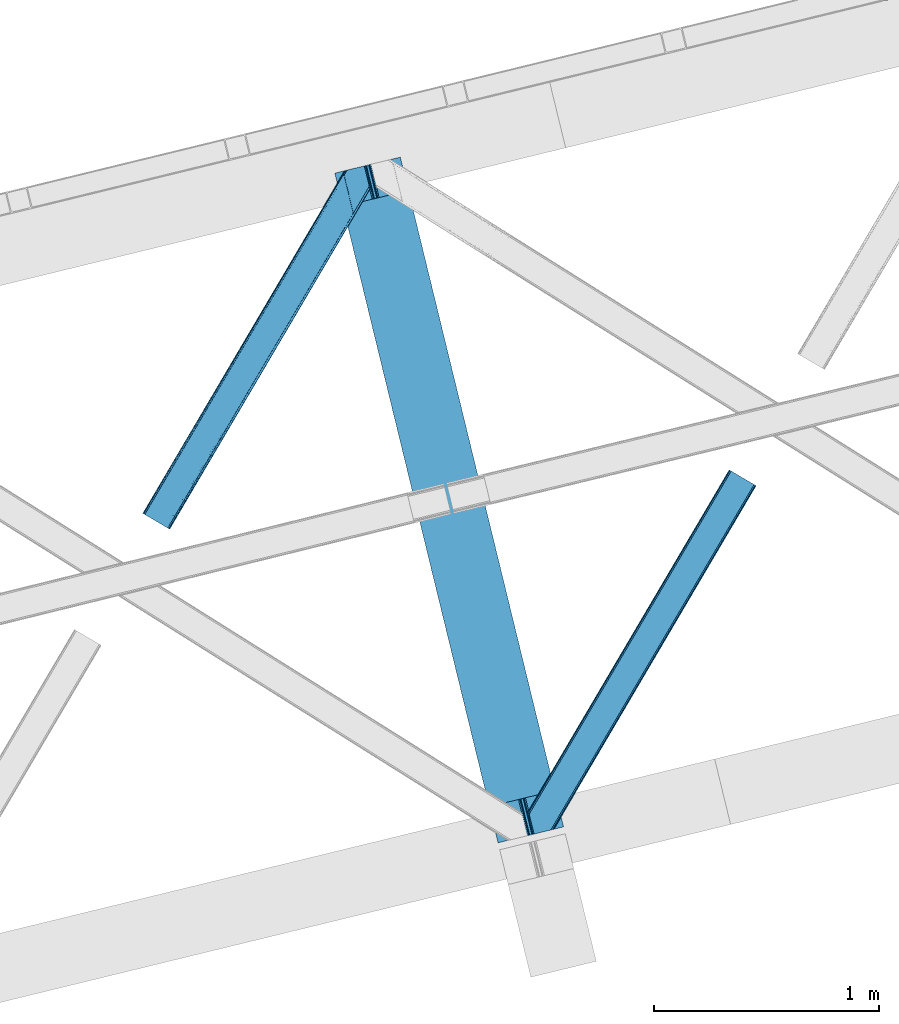
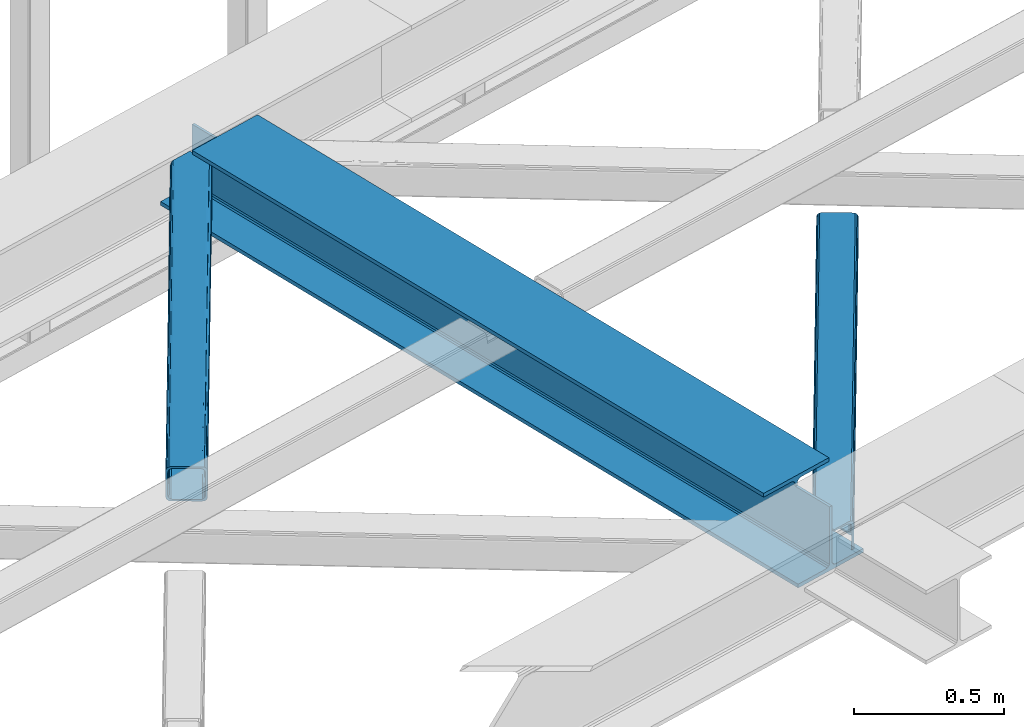
# One storey, part 23 of 67: 2 members, 1 beam.
"""IFC4 building model written with IfcOpenShell, lengths in millimetres."""

from ifc_helpers import new_model, entity, si_unit, converted_unit, derived_unit, direction, frame, origin, place, context, subcontext, project, spatial, triangles, polygons, material, type_object, element, save


model = new_model("IFC4")

# Units and contexts
model_context = context("Model", 3, precision=0.01, world=origin(), true_north=direction((6.12303176911189e-17, 1.0)))
plan_context = context("Plan", 3, precision=0.01, world=origin(), true_north=direction((6.12303176911189e-17, 1.0)))
body_context = subcontext(model_context, "Body", "Model", "MODEL_VIEW")
ifc_project = project(units=[si_unit("LENGTHUNIT", "METRE", prefix="MILLI"), si_unit("AREAUNIT", "SQUARE_METRE"), si_unit("VOLUMEUNIT", "CUBIC_METRE"), converted_unit("PLANEANGLEUNIT", "DEGREE", entity("IfcRatioMeasure", 0.0174532925199433), si_unit("PLANEANGLEUNIT", "RADIAN"), dimensions=[0, 0, 0, 0, 0, 0, 0]), si_unit("MASSUNIT", "GRAM", prefix="KILO"), derived_unit("MASSDENSITYUNIT", [(si_unit("MASSUNIT", "GRAM", prefix="KILO"), 1), (si_unit("LENGTHUNIT", "METRE"), -3)]), derived_unit("MOMENTOFINERTIAUNIT", [(si_unit("LENGTHUNIT", "METRE"), 4)]), si_unit("TIMEUNIT", "SECOND"), si_unit("FREQUENCYUNIT", "HERTZ"), si_unit("THERMODYNAMICTEMPERATUREUNIT", "DEGREE_CELSIUS"), derived_unit("THERMALTRANSMITTANCEUNIT", [(si_unit("MASSUNIT", "GRAM", prefix="KILO"), 1), (si_unit("THERMODYNAMICTEMPERATUREUNIT", "KELVIN"), -1), (si_unit("TIMEUNIT", "SECOND"), -3)]), derived_unit("VOLUMETRICFLOWRATEUNIT", [(si_unit("LENGTHUNIT", "METRE"), 3), (si_unit("TIMEUNIT", "SECOND"), -1)]), derived_unit("MASSFLOWRATEUNIT", [(si_unit("MASSUNIT", "GRAM", prefix="KILO"), 1), (si_unit("TIMEUNIT", "SECOND"), -1)]), derived_unit("ROTATIONALFREQUENCYUNIT", [(si_unit("TIMEUNIT", "SECOND"), -1)]), si_unit("ELECTRICCURRENTUNIT", "AMPERE"), si_unit("ELECTRICVOLTAGEUNIT", "VOLT"), si_unit("POWERUNIT", "WATT"), si_unit("FORCEUNIT", "NEWTON", prefix="KILO"), si_unit("ILLUMINANCEUNIT", "LUX"), si_unit("LUMINOUSFLUXUNIT", "LUMEN"), si_unit("LUMINOUSINTENSITYUNIT", "CANDELA"), derived_unit("USERDEFINED", [(si_unit("MASSUNIT", "GRAM", prefix="KILO"), -1), (si_unit("LENGTHUNIT", "METRE"), -2), (si_unit("TIMEUNIT", "SECOND"), 3), (si_unit("LUMINOUSFLUXUNIT", "LUMEN"), 1)]), derived_unit("LINEARVELOCITYUNIT", [(si_unit("LENGTHUNIT", "METRE"), 1), (si_unit("TIMEUNIT", "SECOND"), -1)]), si_unit("PRESSUREUNIT", "PASCAL"), derived_unit("USERDEFINED", [(si_unit("LENGTHUNIT", "METRE"), -2), (si_unit("MASSUNIT", "GRAM", prefix="KILO"), 1), (si_unit("TIMEUNIT", "SECOND"), -2)]), derived_unit("LINEARFORCEUNIT", [(si_unit("MASSUNIT", "GRAM", prefix="KILO"), 1), (si_unit("LENGTHUNIT", "METRE"), 1), (si_unit("TIMEUNIT", "SECOND"), -2), (si_unit("LENGTHUNIT", "METRE"), -1)]), derived_unit("PLANARFORCEUNIT", [(si_unit("MASSUNIT", "GRAM", prefix="KILO"), 1), (si_unit("LENGTHUNIT", "METRE"), 1), (si_unit("TIMEUNIT", "SECOND"), -2), (si_unit("LENGTHUNIT", "METRE"), -2)])], contexts=[model_context, plan_context])

# Site, building, storey
site_placement = place(None, origin())
site = spatial("IfcSite", under=ifc_project, at=site_placement, CompositionType="ELEMENT")
building_placement = place(site_placement, origin())
building = spatial("IfcBuilding", under=site, at=building_placement, CompositionType="ELEMENT")
storey_placement = place(building_placement, frame((0.0, 0.0, 19800.0)))
storey = spatial("IfcBuildingStorey", under=building, at=storey_placement, CompositionType="ELEMENT", Elevation=19800.0)

# Beam
ifc_material = material(Name="Metal painted (White)")
beam_type = type_object("IfcBeamType", PredefinedType="BEAM")
beam_placement = place(storey_placement, frame((-52407.8389725315, 5019.96399908026, 3807.02022389142)))
element("IfcBeam", 1, at=beam_placement, inside=storey, type_object=beam_type, material=ifc_material, ObjectType="Steel Beam", PredefinedType="BEAM", context=body_context, shape_type="Tessellation", body=[
    polygons([(1018.16648378329, 71.0478278971, 15.5000000000008), (1018.16648378329, 71.0478278971, 0.0), (291.465617442446, 3052.25531830421, 0.0), (291.465617442446, 3052.25531830421, 15.5000000000008), (894.779372399338, 40.970914087327, 15.5000000000008), (168.078506058482, 3022.17840449444, 15.5000000000008), (888.087028625384, 39.3395844888221, 16.8701684147984), (161.38616228452, 3020.54707489594, 16.8701684147984), (882.413533524751, 37.9566100336497, 20.7720779386434), (155.712667183895, 3019.16410044076, 20.7720779386434), (878.622625296184, 37.0325360459162, 26.6116982174294), (151.921758955338, 3018.24002645303, 26.6116982174294), (877.291435352779, 36.7080444135018, 33.500000000001), (150.590569011924, 3017.91553482061, 33.500000000001), (140.875048430514, 3015.54727389071, 33.500000000001), (140.875048430514, 3015.54727389071, 259.000000000002), (150.590569011932, 3017.91553482061, 259.000000000002), (-8.66293703438714e-12, 2981.20749040711, 0.0), (8.66293703438714e-12, 2981.20749040711, 15.4999999999965), (123.387111383964, 3011.28440421688, 15.5000000000008), (130.079455157926, 3012.91573381539, 16.8701684147984), (135.752950258542, 3014.29870827056, 20.7720779386434), (139.543858487117, 3015.2227822583, 26.6116982174294), (877.291435352779, 36.7080444135018, 259.000000000002), (867.575914771369, 34.3397834835981, 259.000000000002), (867.575914771369, 34.3397834835981, 33.500000000001), (866.244724827964, 34.0152918511827, 26.6116982174294), (862.453816599389, 33.0912178634492, 20.7720779386434), (856.780321498782, 31.7082434082767, 16.8701684147984), (850.087977724819, 30.0769138097719, 15.5000000000008), (726.700866340855, -1.08286712929839e-12, 15.4999999999965), (726.700866340855, -1.08286712929839e-12, 0.0), (838.124523615921, 197.385937999178, 259.069791973884), (186.469722099971, 2870.72539801218, 259.000000000002), (186.69311520182, 2869.80895360721, 259.617303331124), (186.705504045454, 2869.75812937344, 266.500003008253), (837.979344808147, 197.981416001702, 266.500002998871), (837.979694928899, 197.979979696967, 260.000004007589), (828.499586345876, 194.645865944428, 259.006343171919), (828.276216326111, 195.562317481909, 259.617303331124), (828.263827482477, 195.613141715681, 266.500003008253), (176.989986719784, 2867.38985508742, 266.500002998871), (176.98963659904, 2867.39129139215, 260.000004007589), (176.844830940696, 2867.98534020594, 259.07612046749), (176.754201518561, 2868.35713708228, 259.000000000002), (839.310832678066, 198.304685446387, 273.388305639783), (843.101109266762, 199.231350618301, 279.227924098781), (848.7741802143, 200.616065081978, 283.129832400619), (855.466371895425, 202.248018612791, 284.500000377228), (978.853400583278, 232.325271667903, 284.500000138971), (978.851730776618, 232.332121736635, 299.999995328161), (687.386308679347, 161.283492472592, 299.999995890962), (687.387978485999, 161.27664240386, 284.500000701776), (810.775007173852, 191.353895458972, 284.500000463519), (817.46749406999, 192.98463792555, 283.129832461069), (823.141405718742, 194.365903570075, 279.227924137322), (826.932940505742, 195.287407219373, 273.388305663684), (175.658498849857, 2867.06658564273, 273.388305639783), (171.868222261169, 2866.13992047082, 279.227924098781), (166.195151313631, 2864.75520600714, 283.129832400619), (159.502959632497, 2863.12325247633, 284.500000377228), (36.1159309446533, 2833.04599942122, 284.500000138971), (36.117600751305, 2833.03914935249, 299.999995328161), (327.583022848584, 2904.08777861653, 299.999995890962), (327.581353041932, 2904.09462868526, 284.500000701776), (204.194324354088, 2874.01737563015, 284.500000463519), (197.501837457941, 2872.38663316357, 283.129832461069), (191.827925809189, 2871.00536751905, 279.227924137322), (188.036391022189, 2870.08386386975, 273.388305663684)], [[[1, 2, 3, 4]], [[5, 1, 4, 6]], [[7, 5, 6, 8]], [[9, 7, 8, 10]], [[11, 9, 10, 12]], [[13, 11, 12, 14]], [[15, 16, 17, 14, 12, 10, 8, 6, 4, 3, 18, 19, 20, 21, 22, 23]], [[13, 24, 25, 26, 27, 28, 29, 30, 31, 32, 2, 1, 5, 7, 9, 11]], [[2, 32, 18, 3]], [[32, 31, 19, 18]], [[31, 30, 20, 19]], [[27, 26, 15, 23]], [[28, 27, 23, 22]], [[29, 28, 22, 21]], [[30, 29, 21, 20]], [[33, 24, 13, 14, 17, 34, 35, 36, 37, 38]], [[25, 39, 40, 41, 42, 43, 44, 16, 15, 26]], [[39, 25, 24, 33]], [[45, 34, 17, 16]], [[41, 40, 38, 37, 46, 47, 48, 49, 50, 51, 52, 53, 54, 55, 56, 57]], [[42, 58, 59, 60, 61, 62, 63, 64, 65, 66, 67, 68, 69, 36, 35, 43]], [[46, 37, 36, 69]], [[47, 46, 69, 68]], [[48, 47, 68, 67]], [[49, 48, 67, 66]], [[50, 49, 66, 65]], [[51, 50, 65, 64]], [[52, 51, 64, 63]], [[53, 52, 63, 62]], [[54, 53, 62, 61]], [[55, 54, 61, 60]], [[56, 55, 60, 59]], [[57, 56, 59, 58]], [[41, 57, 58, 42]]], closed=False),
])

# Members
member_type_1 = type_object("IfcMemberType", PredefinedType="BRACE")
member_1_placement = place(storey_placement, frame((-53262.9302856445, 6415.9455871582, 3823.99987792968)))
element("IfcMember", 2, at=member_1_placement, inside=storey, type_object=member_type_1, ObjectType="Steel Horizontal Brace", PredefinedType="BRACE", context=body_context, shape_type="Tessellation", body=[
    triangles([(105.565649414064, 8.87852783203107, 0.0), (15.0781494140683, 62.148532104492, 0.0), (892.847827148442, 1346.13992614746, 0.0), (857.166284179693, 1492.50250396729, 0.0), (854.892004394533, 1501.83739929199, 1.33247680664135), (9.31105957031832, 65.5459991455082, 1.33247680664135), (852.961889648439, 1509.75145111084, 5.12526855468968), (4.4183349609375, 68.4266372680668, 5.12526855468968), (851.673596191409, 1515.03950042725, 10.8039916992202), (1.14876708984957, 70.3509384155277, 10.8039916992202), (851.222460937504, 1516.89636383057, 17.5012573242202), (0.0, 71.027059936524, 17.5012573242202), (893.633825683595, 1342.89826354981, 0.155804443358647), (111.332739257814, 5.48106079101581, 1.33247680664135), (899.559045410162, 1344.34178009033, 1.33247680664135), (912.390820312503, 1347.46949615479, 10.8039916992202), (914.195361328129, 1347.90958557129, 17.5012573242202), (120.643798828125, 0.0, 17.5012573242202), (119.495031738283, 0.675540161132631, 10.8039916992202), (907.251599121097, 1346.21666564941, 5.12526855468968), (116.225463867188, 2.60042266845721, 5.12526855468968), (902.493750000001, 1345.05743408203, 17.9802978515618), (893.633825683595, 1342.89826354981, 9.69243164062573), (897.768457031256, 1343.90459747315, 12.1248413085959), (903.721582031256, 1345.35683441162, 19.5011352539077), (914.195361328129, 1347.90958557129, 19.5011352539077), (1011.61732177735, 1513.38669433594, 19.5011352539077), (1008.98957519532, 1524.16103668213, 19.5011352539077), (1011.61732177735, 1513.38669433594, 122.499499511719), (120.643798828125, 0.0, 122.499499511719), (114.61160888672, 3.5515274047857, 24.5008300781265), (1009.23607177735, 1523.14423828125, 24.5008300781265), (113.462841796878, 4.22706756591833, 17.8035644531265), (110.193273925783, 6.15195007324201, 12.1248413085959), (105.300549316409, 9.03200683593786, 8.3320495605476), (99.52880859375, 12.4294738769531, 6.99957275390625), (892.685046386723, 1346.79976959229, 8.8831787109375), (890.466577148443, 1355.89747009277, 6.99957275390625), (21.1103393554731, 58.5975860595709, 6.99957275390625), (859.547534179692, 1482.74496002197, 6.99957275390625), (853.961828613283, 1505.66042175293, 18.501196289064), (851.222460937504, 1516.89636383057, 18.501196289064), (854.096704101568, 1505.10929260254, 17.8803039550803), (855.343139648438, 1499.99390716553, 12.1248413085959), (857.273254394531, 1492.07985534668, 8.3320495605476), (1009.23607177735, 1523.14423828125, 115.499926757813), (114.61160888672, 3.5515274047857, 115.499926757813), (1008.78493652344, 1525.00110168457, 122.197192382813), (113.462841796878, 4.22706756591833, 122.197192382813), (1007.49664306641, 1530.28915100098, 127.873590087893), (110.193273925783, 6.15195007324201, 127.873590087893), (1005.56652832031, 1538.20320281982, 131.668707275392), (105.300549316409, 9.03200683593786, 131.668707275392), (1003.29224853516, 1547.53809814453, 133.001184082033), (99.52880859375, 12.4294738769531, 133.001184082033), (851.952648925784, 1518.13291625977, 19.5011352539077), (854.575744628906, 1507.35857391357, 19.5011352539077), (851.780566406254, 1517.84049224854, 19.2639404296897), (854.426916503908, 1506.95045928955, 19.2592895507805), (851.585229492193, 1517.51434936523, 19.0011657714858), (854.268786621098, 1506.50920715332, 19.0011657714858), (851.394543457034, 1517.1887878418, 18.7360656738274), (854.110656738281, 1506.06853637695, 18.7407165527366), (908.014343261719, 1598.12687072754, 19.5011352539077), (897.540563964845, 1595.57411956787, 19.5011352539077), (1011.16618652344, 1515.24355773926, 129.196765136719), (1009.8732421875, 1520.53160705566, 134.87548828125), (1008.43146972657, 1526.45624542236, 138.000878906252), (986.307238769536, 1617.21175231934, 138.000878906252), (986.307238769536, 1617.21175231934, 133.001184082033), (897.540563964845, 1595.57411956787, 122.499499511719), (0.0, 71.027059936524, 122.499499511719), (7.18095703125437, 66.7999923706057, 17.8035644531265), (10.4505249023496, 64.8751098632811, 12.1248413085959), (6.03218994141207, 67.4755325317383, 24.5008300781265), (907.023706054693, 1597.88560638428, 24.5008300781265), (15.3432495117231, 61.9944717407225, 8.3320495605476), (908.832897949222, 1598.32569580078, 122.197192382813), (899.345104980472, 1596.01362762451, 129.196765136719), (904.484326171878, 1597.26645812988, 134.87548828125), (930.73388671875, 1603.66548614502, 133.001184082033), (910.246765136719, 1598.67044219971, 138.000878906252), (921.664672851563, 1601.45341186523, 131.668707275392), (913.972119140628, 1599.57852630615, 127.873590087893), (907.023706054693, 1597.88560638428, 115.499926757813), (21.1103393554731, 58.5975860595709, 133.001184082033), (6.03218994141207, 67.4755325317383, 115.499926757813), (15.3432495117231, 61.9944717407225, 131.668707275392), (10.4505249023496, 64.8751098632811, 127.873590087893), (7.18095703125437, 66.7999923706057, 122.197192382813), (119.495031738283, 0.675540161132631, 129.196765136719), (116.225463867188, 2.60042266845721, 134.87548828125), (111.332739257814, 5.48106079101581, 138.668280029298), (105.565649414064, 8.87852783203107, 140.00075683594), (15.0781494140683, 62.148532104492, 140.00075683594), (9.31105957031832, 65.5459991455082, 138.668280029298), (4.4183349609375, 68.4266372680668, 134.87548828125), (1.14876708984957, 70.3509384155277, 129.196765136719), (896.991760253906, 1576.15611877441, 138.000878906252), (938.18924560547, 1407.14434204102, 138.000878906252), (899.024194335943, 1563.59525756836, 140.00075683594), (897.042919921878, 1571.72266845703, 139.000817871096), (896.796423339845, 1573.13711700439, 138.638049316407), (896.926647949222, 1575.15443572998, 138.212493896484), (896.861535644537, 1574.14170684815, 138.426434326171), (937.473010253911, 1407.08562469482, 138.293884277344), (937.077685546879, 1408.09486541748, 138.647351074218), (936.682360839848, 1409.10410614014, 139.000817871096), (934.701086425783, 1417.23267974854, 140.00075683594)], [[1, 2, 3], [4, 3, 2], [5, 4, 6], [2, 6, 4], [7, 5, 8], [6, 8, 5], [9, 7, 10], [8, 10, 7], [11, 9, 12], [10, 12, 9], [1, 3, 13], [13, 14, 1], [13, 15, 14], [16, 17, 18], [18, 19, 16], [20, 16, 19], [19, 21, 20], [15, 20, 21], [21, 14, 15], [20, 22, 16], [23, 24, 15], [23, 15, 13], [15, 24, 20], [16, 25, 17], [20, 24, 22], [16, 22, 25], [26, 17, 25], [26, 25, 27], [28, 27, 25], [27, 29, 26], [30, 26, 29], [26, 18, 17], [30, 18, 26], [31, 32, 25], [25, 33, 31], [25, 22, 33], [32, 28, 25], [33, 22, 24], [34, 24, 23], [23, 35, 34], [36, 35, 37], [37, 38, 36], [23, 37, 35], [24, 34, 33], [39, 36, 38], [38, 40, 39], [9, 11, 41], [11, 42, 41], [43, 9, 41], [43, 7, 9], [44, 7, 43], [5, 44, 45], [44, 5, 7], [4, 5, 45], [45, 40, 4], [37, 23, 13], [37, 3, 38], [3, 40, 38], [40, 3, 4], [37, 13, 3], [46, 32, 31], [31, 47, 46], [48, 46, 49], [47, 49, 46], [50, 48, 51], [49, 51, 48], [52, 50, 53], [51, 53, 50], [54, 52, 55], [53, 55, 52], [56, 57, 58], [59, 58, 57], [58, 59, 60], [61, 60, 59], [60, 61, 62], [63, 62, 61], [62, 63, 42], [41, 42, 63], [57, 56, 64], [65, 64, 56], [66, 48, 67], [46, 29, 27], [27, 32, 46], [32, 27, 28], [48, 29, 46], [66, 29, 48], [50, 68, 67], [52, 68, 50], [67, 48, 50], [52, 54, 68], [54, 69, 68], [70, 69, 54], [71, 60, 62], [58, 60, 71], [71, 56, 58], [56, 71, 65], [42, 12, 72], [12, 42, 11], [71, 42, 72], [42, 71, 62], [73, 74, 44], [75, 73, 43], [43, 41, 75], [43, 57, 75], [64, 76, 57], [75, 57, 76], [44, 43, 73], [45, 44, 74], [74, 77, 45], [40, 45, 77], [77, 39, 40], [78, 79, 80], [81, 82, 69], [69, 70, 81], [81, 83, 82], [84, 82, 83], [80, 82, 84], [78, 71, 79], [85, 71, 78], [80, 84, 78], [65, 76, 64], [85, 65, 71], [76, 65, 85], [86, 54, 55], [54, 86, 81], [70, 54, 81], [76, 85, 87], [87, 75, 76], [83, 81, 86], [86, 88, 83], [84, 83, 88], [88, 89, 84], [78, 84, 89], [89, 90, 78], [85, 78, 90], [90, 87, 85], [91, 51, 49], [47, 18, 30], [91, 49, 30], [91, 92, 51], [49, 47, 30], [51, 92, 93], [55, 94, 95], [94, 53, 93], [53, 94, 55], [53, 51, 93], [19, 34, 21], [31, 18, 47], [18, 33, 19], [33, 18, 31], [19, 33, 34], [1, 36, 2], [14, 21, 34], [34, 35, 14], [35, 36, 1], [1, 14, 35], [89, 96, 97], [95, 86, 55], [95, 88, 86], [88, 95, 96], [89, 88, 96], [87, 72, 12], [98, 90, 89], [97, 98, 89], [90, 98, 72], [87, 90, 72], [6, 74, 8], [2, 36, 39], [39, 77, 2], [77, 74, 6], [6, 2, 77], [10, 8, 74], [12, 75, 87], [73, 12, 10], [12, 73, 75], [73, 10, 74], [99, 68, 82], [99, 100, 68], [68, 69, 82], [96, 95, 101], [101, 102, 96], [97, 96, 103], [104, 97, 105], [104, 99, 97], [97, 103, 105], [82, 80, 99], [97, 99, 80], [102, 103, 96], [79, 71, 98], [72, 98, 71], [80, 79, 97], [98, 97, 79], [92, 67, 100], [100, 93, 92], [67, 68, 100], [106, 107, 93], [94, 93, 107], [107, 108, 94], [108, 109, 94], [66, 67, 92], [92, 91, 66], [29, 66, 91], [91, 30, 29], [95, 94, 109], [109, 101, 95], [107, 103, 102], [105, 103, 107], [106, 104, 105], [100, 99, 104], [107, 106, 105], [102, 108, 107], [102, 101, 109], [109, 108, 102]]),
])
member_type_2 = type_object("IfcMemberType", PredefinedType="BRACE")
member_2_placement = place(storey_placement, frame((-51546.0815917969, 5059.05399169922, 3823.99987792968)))
element("IfcMember", 3, at=member_2_placement, inside=storey, type_object=member_type_2, ObjectType="Steel Horizontal Brace", PredefinedType="BRACE", context=body_context, shape_type="Tessellation", body=[
    triangles([(154.446386718751, 124.70924835205, 0.0), (118.769494628912, 271.071826171875, 0.0), (998.971582031256, 1559.19901428223, 0.0), (908.484082031253, 1612.46901855469, 0.0), (1004.73867187501, 1555.80154724121, 1.33247680664135), (156.720666503912, 115.37377166748, 1.33247680664135), (1009.63604736328, 1552.92090911865, 5.12526855468968), (158.650781250006, 107.459719848633, 5.12526855468968), (1012.90096435547, 1550.99602661133, 10.8039916992202), (159.939074707036, 102.17225189209, 10.8039916992202), (1014.04973144532, 1550.32048645019, 17.5012573242202), (160.39020996094, 100.315388488769, 17.5012573242202), (902.716992187503, 1615.8664855957, 1.33247680664135), (116.495214843751, 280.406721496582, 1.33247680664135), (114.574401855469, 288.276008605957, 5.1694519042976), (897.824267578129, 1618.74712371826, 5.12526855468968), (114.495336914064, 288.596919250488, 5.32758178711083), (894.554699707034, 1620.67142486572, 10.8039916992202), (109.625866699222, 287.409201049804, 10.8039916992202), (893.405932617192, 1621.34754638672, 17.5012573242202), (107.821325683595, 286.969692993163, 17.5012573242202), (113.523303222661, 288.360305786133, 18.5197998046897), (114.495336914064, 288.596919250488, 17.5198608398459), (114.420922851568, 288.578897094726, 17.9035583496116), (114.211633300787, 288.527737426757, 18.2267944335945), (113.895373535161, 288.450416564941, 18.4453857421868), (107.821325683595, 286.969692993163, 18.5197998046897), (115.695263671878, 283.683847045898, 17.5198608398459), (115.625500488284, 283.800700378418, 17.8035644531265), (115.565039062501, 283.7408203125, 17.8570495605491), (115.318542480469, 283.496067810058, 18.0779663085959), (115.067395019534, 283.239688110351, 18.3081848144539), (114.830200195313, 283.003656005859, 18.5197998046897), (0.0, 103.825057983398, 18.5197998046897), (2.73471679687646, 92.5989990234375, 18.5197998046897), (893.405932617192, 1621.34754638672, 122.499499511719), (0.0, 103.825057983398, 122.499499511719), (908.484082031253, 1612.46901855469, 140.00075683594), (902.716992187503, 1615.8664855957, 138.668280029298), (3.66954345703562, 88.766093444824, 138.668280029298), (5.94382324218896, 79.4311981201172, 140.00075683594), (897.824267578129, 1618.74712371826, 134.87548828125), (1.73942871094187, 96.6801452636719, 134.87548828125), (894.554699707034, 1620.67142486572, 129.196765136719), (0.451135253912071, 101.968194580078, 129.196765136719), (899.438122558597, 1617.79601898193, 24.5008300781265), (2.37659912109666, 94.0675140380854, 24.5008300781265), (900.586889648439, 1617.1204788208, 17.8035644531265), (903.856457519534, 1615.19559631348, 12.1248413085959), (914.516271972658, 1608.9174911499, 6.99957275390625), (908.749182128908, 1612.31553955078, 8.3320495605476), (118.871813964848, 270.64917755127, 8.3320495605476), (121.146093750001, 261.314282226562, 6.99957275390625), (116.941699218754, 278.563229370116, 12.1248413085959), (152.069787597662, 134.466792297363, 6.99957275390625), (992.939392089844, 1562.75054168701, 6.99957275390625), (156.274182128909, 117.217263793945, 12.1248413085959), (154.344067382815, 125.131315612793, 8.3320495605476), (157.520617675786, 112.097227478027, 17.5198608398459), (160.39020996094, 100.315388488769, 17.5198608398459), (899.438122558597, 1617.79601898193, 115.499926757813), (2.37659912109666, 94.0675140380854, 115.499926757813), (900.586889648439, 1617.1204788208, 122.197192382813), (2.82773437500146, 92.2106506347654, 122.197192382813), (903.856457519534, 1615.19559631348, 127.873590087893), (4.12067871094041, 86.9226013183588, 127.873590087893), (908.749182128908, 1612.31553955078, 131.668707275392), (6.046142578125, 79.008549499511, 131.668707275392), (914.516271972658, 1608.9174911499, 133.001184082033), (8.3250732421875, 69.6736541748041, 133.001184082033), (25.3054321289092, 0.0, 133.001184082033), (25.3054321289092, 0.0, 140.00075683594), (90.3619262695356, 15.8583343505852, 140.00075683594), (998.971582031256, 1559.19901428223, 140.00075683594), (1014.04973144532, 1550.32048645019, 122.499499511719), (1012.90096435547, 1550.99602661133, 129.196765136719), (114.0721069336, 21.6382141113281, 122.499499511719), (112.267565917973, 21.1981246948235, 129.196765136719), (1009.63604736328, 1552.92090911865, 134.87548828125), (107.128344726567, 19.9452941894524, 134.87548828125), (1004.73867187501, 1555.80154724121, 138.668280029298), (99.435791015625, 18.0698272705076, 138.668280029298), (159.664672851563, 99.0788360595698, 18.5197998046897), (114.0721069336, 21.6382141113281, 18.5197998046897), (103.161145019534, 18.9784927368164, 18.5197998046897), (156.929956054693, 110.304895019531, 18.5197998046897), (1008.01754150391, 1553.87201385498, 24.5008300781265), (1006.86877441406, 1554.54755401611, 17.8035644531265), (157.222961425781, 111.200770568847, 18.0198303222678), (1003.60385742188, 1556.47243652344, 12.1248413085959), (998.706481933594, 1559.35249328613, 8.3320495605476), (104.588964843751, 19.3261459350579, 24.5008300781265), (1003.60385742188, 1556.47243652344, 127.873590087893), (1008.01754150391, 1553.87201385498, 115.499926757813), (1006.86877441406, 1554.54755401611, 122.197192382813), (992.939392089844, 1562.75054168701, 133.001184082033), (998.706481933594, 1559.35249328613, 131.668707275392), (102.784423828125, 18.8860565185541, 122.197192382813), (80.8787841796875, 13.5468475341795, 133.001184082033), (89.9526489257842, 15.758340454101, 131.668707275392), (97.6452026367188, 17.633226013183, 127.873590087893), (104.588964843751, 19.3261459350579, 115.499926757813)], [[1, 2, 3], [4, 3, 2], [3, 5, 1], [6, 1, 5], [5, 7, 6], [8, 6, 7], [7, 9, 8], [10, 8, 9], [9, 11, 10], [12, 10, 11], [13, 14, 15], [16, 15, 17], [17, 18, 16], [17, 19, 18], [20, 18, 19], [19, 21, 20], [15, 16, 13], [13, 4, 14], [2, 14, 4], [22, 23, 24], [22, 25, 26], [27, 21, 22], [24, 25, 22], [23, 22, 21], [21, 19, 23], [17, 23, 19], [23, 28, 29], [29, 24, 23], [25, 24, 30], [26, 25, 31], [22, 26, 32], [32, 33, 22], [31, 32, 26], [30, 31, 25], [29, 30, 24], [34, 33, 35], [33, 34, 27], [22, 33, 27], [27, 20, 21], [36, 27, 37], [27, 36, 20], [27, 34, 37], [38, 39, 40], [40, 41, 38], [39, 42, 43], [43, 40, 39], [42, 44, 45], [45, 43, 42], [44, 36, 37], [37, 45, 44], [46, 47, 33], [33, 48, 46], [33, 31, 48], [47, 35, 33], [49, 48, 28], [50, 51, 52], [52, 53, 50], [51, 49, 54], [54, 52, 51], [28, 54, 49], [53, 55, 56], [56, 50, 53], [55, 2, 1], [54, 17, 14], [52, 14, 2], [52, 2, 53], [55, 53, 2], [17, 28, 23], [54, 28, 17], [52, 54, 14], [57, 58, 6], [58, 1, 6], [1, 58, 55], [8, 57, 6], [8, 59, 57], [10, 59, 8], [10, 60, 59], [46, 61, 47], [62, 47, 61], [61, 63, 62], [64, 62, 63], [63, 65, 64], [66, 64, 65], [65, 67, 66], [68, 66, 67], [67, 69, 68], [70, 68, 69], [66, 43, 64], [71, 72, 70], [72, 41, 70], [40, 68, 41], [66, 68, 40], [68, 70, 41], [66, 40, 43], [37, 34, 62], [45, 64, 43], [62, 64, 37], [64, 45, 37], [34, 47, 62], [34, 35, 47], [41, 73, 74], [73, 41, 72], [74, 38, 41], [75, 76, 77], [78, 77, 76], [76, 79, 78], [80, 78, 79], [79, 81, 80], [82, 80, 81], [81, 74, 82], [73, 82, 74], [60, 75, 77], [60, 11, 75], [77, 83, 60], [77, 84, 83], [84, 85, 83], [86, 83, 85], [87, 88, 59], [89, 86, 87], [88, 90, 57], [57, 59, 88], [90, 91, 58], [58, 57, 90], [91, 56, 55], [55, 58, 91], [87, 86, 92], [85, 92, 86], [9, 90, 88], [87, 75, 11], [9, 88, 11], [9, 7, 90], [88, 87, 11], [90, 7, 5], [56, 3, 4], [3, 91, 5], [91, 3, 56], [91, 90, 5], [76, 93, 79], [94, 75, 87], [75, 95, 76], [95, 75, 94], [76, 95, 93], [74, 96, 38], [81, 79, 93], [93, 97, 81], [97, 96, 74], [74, 81, 97], [49, 13, 16], [4, 50, 56], [4, 51, 50], [51, 4, 13], [49, 51, 13], [46, 20, 36], [18, 48, 49], [16, 18, 49], [48, 18, 20], [46, 48, 20], [39, 65, 42], [38, 96, 69], [69, 67, 38], [67, 65, 39], [39, 38, 67], [44, 42, 65], [36, 61, 46], [63, 36, 44], [36, 63, 61], [63, 44, 65], [98, 78, 80], [99, 73, 72], [72, 71, 99], [99, 100, 73], [100, 82, 73], [101, 82, 100], [80, 82, 101], [98, 77, 78], [102, 77, 98], [80, 101, 98], [84, 92, 85], [102, 84, 77], [92, 84, 102], [99, 70, 96], [99, 71, 70], [69, 96, 70], [96, 97, 100], [100, 99, 96], [97, 93, 101], [101, 100, 97], [93, 95, 98], [98, 101, 93], [95, 94, 102], [102, 98, 95], [94, 87, 92], [92, 102, 94]]),
])

save(model, "model.ifc")
